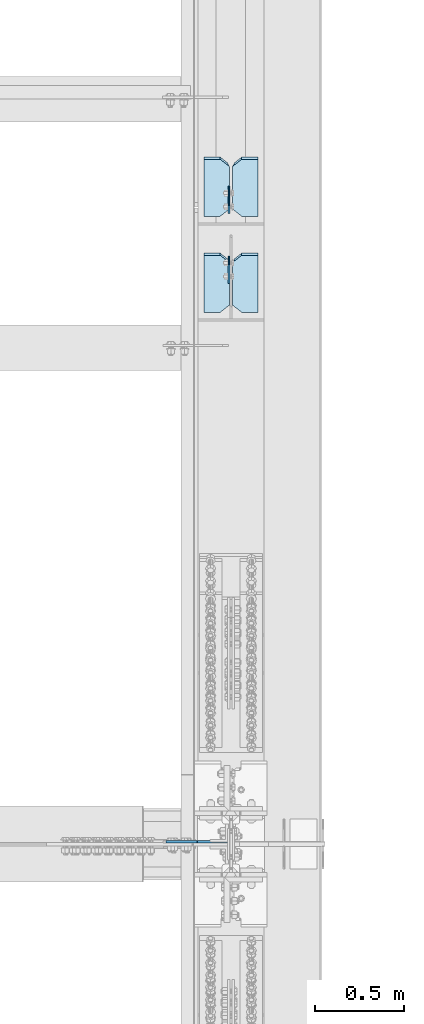
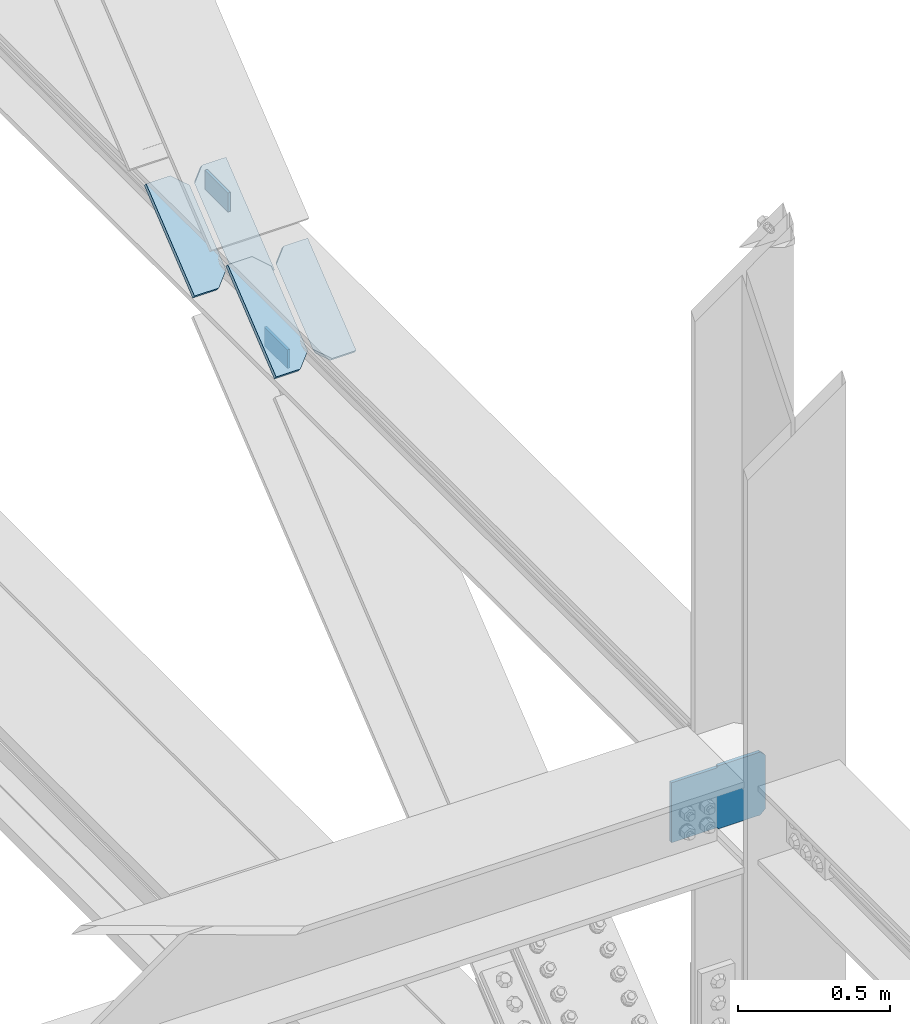
# One storey, part 3608 of 3843: 7 plates, 2 elements without a shape of their own.
"""IFC2X3 building model written with IfcOpenShell, lengths in millimetres."""

from ifc_helpers import new_model, si_unit, frame, origin_with_axes, place, context, subcontext, project, spatial, faceted_brep, material, type_object, element, aggregate, save


model = new_model("IFC2X3")

# Units and contexts
model_context = context("Model", 3, precision=1e-05, world=origin_with_axes())
body_context = subcontext(model_context, "Body", "Model", "MODEL_VIEW")
ifc_project = project(units=[si_unit("LENGTHUNIT", "METRE", prefix="MILLI"), si_unit("AREAUNIT", "SQUARE_METRE"), si_unit("VOLUMEUNIT", "CUBIC_METRE"), si_unit("MASSUNIT", "GRAM", prefix="KILO"), si_unit("TIMEUNIT", "SECOND"), si_unit("PLANEANGLEUNIT", "RADIAN"), si_unit("SOLIDANGLEUNIT", "STERADIAN"), si_unit("THERMODYNAMICTEMPERATUREUNIT", "DEGREE_CELSIUS"), si_unit("LUMINOUSINTENSITYUNIT", "LUMEN")], contexts=[model_context])

# Site, building, storey
site_placement = place(None, origin_with_axes())
site = spatial("IfcSite", under=ifc_project, at=site_placement, CompositionType="ELEMENT")
building_placement = place(site_placement, origin_with_axes())
building = spatial("IfcBuilding", under=site, at=building_placement, Name="Undefined", CompositionType="ELEMENT")
storey_placement = place(building_placement, origin_with_axes())
storey = spatial("IfcBuildingStorey", under=building, at=storey_placement, Name="Undefined", CompositionType="ELEMENT", Elevation=0.0)

# Assembly, plates
assembly_1_placement = place(storey_placement, origin_with_axes())
assembly_1 = element("IfcElementAssembly", 1, at=assembly_1_placement, inside=storey, Name="BEAM", AssemblyPlace="NOTDEFINED", PredefinedType="RIGID_FRAME")
ifc_material = material(Name="STEEL/A572-50")
plate_type_1 = type_object("IfcPlateType", PredefinedType="NOTDEFINED")
plate_1_placement = place(assembly_1_placement, frame((85637.6875, 62213.744979419, 42161.687695586), z_axis=(0.0, 0.000523622999971848, -0.999999862909468), x_axis=(0.0, -0.999999862909468, -0.000523622999970077)))
plate_1 = element("IfcPlate", 2, at=plate_1_placement, type_object=plate_type_1, material=ifc_material, Name="PLATE", context=body_context, shape_type="Brep", body=[
    faceted_brep([(0.0, -4.76249999999709, 0.0), (-3.49245965480804e-10, -4.76249999999709, 76.1999999999462), (-3.49245965480804e-10, 4.76249999999709, 76.1999999999462), (0.0, 4.76249999999709, 0.0), (152.399999999543, -4.76249999999709, 76.199999999495), (152.399999999543, 4.76249999999709, 76.199999999495), (152.399993896484, -4.76249999999709, 0.0), (152.399993896484, 4.76249999999709, 0.0)], [[[0, 1, 2, 3]], [[1, 4, 5, 2]], [[4, 6, 7, 5]], [[6, 0, 3, 7]], [[5, 7, 3, 2]], [[6, 4, 1, 0]]]),
])
plate_2_placement = place(assembly_1_placement, frame((85637.6875, 62605.6469707386, 42555.0432467232), z_axis=(0.0, 0.000523622999971848, -0.999999862909468), x_axis=(0.0, -0.999999862909468, -0.000523622999970077)))
plate_2 = element("IfcPlate", 3, at=plate_2_placement, type_object=plate_type_1, material=ifc_material, Name="PLATE", context=body_context, shape_type="Brep", body=[
    faceted_brep([(0.0, -4.76249999999709, 0.0), (-3.49245965480804e-10, -4.76249999999709, 76.1999999999462), (-3.49245965480804e-10, 4.76249999999709, 76.1999999999462), (0.0, 4.76249999999709, 0.0), (152.399999999543, -4.76249999999709, 76.199999999495), (152.399999999543, 4.76249999999709, 76.199999999495), (152.399993896484, -4.76249999999709, 0.0), (152.399993896484, 4.76249999999709, 0.0)], [[[0, 1, 2, 3]], [[1, 4, 5, 2]], [[4, 6, 7, 5]], [[6, 0, 3, 7]], [[5, 7, 3, 2]], [[6, 4, 1, 0]]]),
])

# Assembly, plate
assembly_2_placement = place(storey_placement, origin_with_axes())
assembly_2 = element("IfcElementAssembly", 4, at=assembly_2_placement, inside=storey, Name="COLUMN", AssemblyPlace="NOTDEFINED", PredefinedType="RIGID_FRAME")
plate_type_2 = type_object("IfcPlateType", PredefinedType="NOTDEFINED")
plate_3_placement = place(assembly_2_placement, frame((85640.8625, 58928.7937500954, 42215.4247183178), z_axis=(-0.707106781186548, 0.0, 0.707106781186548), x_axis=(-0.707106781186548, 0.0, -0.707106781186548)))
plate_3 = element("IfcPlate", 5, at=plate_3_placement, type_object=plate_type_2, material=ifc_material, Name="PLATE", context=body_context, shape_type="Brep", body=[
    faceted_brep([(0.0, -6.3499999046162, 0.0), (-152.665622612301, -6.34999999999854, 152.66562261237), (-152.665622612301, 6.34999999999854, 152.66562261237), (7.27595761418343e-12, 6.3499999046162, 0.0), (-152.66562261201, -6.34999999999854, 179.606390975739), (-152.66562261201, 6.34999999999854, 179.606390975739), (-39.2898891266959, -6.34999999999854, 292.982124550974), (-39.2898891266959, 6.34999999999854, 292.982124550974), (-37.2498776379362, -6.34999999999854, 291.619032453094), (-37.2498776379362, 6.34999999999854, 291.619032453094), (-34.8435200147651, -6.34999999999854, 291.140378161515), (-34.8435200147651, 6.34999999999854, 291.140378161515), (-32.4371623915649, -6.34999999999854, 291.619032453116), (-32.4371623915649, 6.34999999999854, 291.619032453116), (-30.3971509028197, -6.34999999999854, 292.982124551017), (-30.3971509028197, 6.34999999999854, 292.982124551017), (90.8800656821986, -6.34999999999854, 414.259341135985), (90.8800656821986, 6.34999999999854, 414.259341135985), (261.504931981661, -6.34999999999854, 243.634474836461), (261.504931981661, 6.34999999999854, 243.634474836461), (140.316501947716, -6.34999999999854, 122.446044802567), (140.316501947716, 6.34999999999854, 122.446044802567), (138.926191181483, -6.34999999999854, 120.365297697925), (138.926191181483, 6.34999999999854, 120.365297697925), (138.437978964605, -6.34999999999854, 117.910889139548), (138.437978964605, 6.34999999999854, 117.910889139548), (138.926191181454, -6.34999999999854, 115.456480581168), (138.926191181454, 6.34999999999854, 115.456480581168), (140.316501893642, -6.34999999999854, 113.375733530571), (140.316501893642, 6.34999999999854, 113.375733530571), (26.9407683632217, -6.34999999999854, 1.30967237055302e-10), (26.9407683632217, 6.34999999999854, 1.30967237055302e-10)], [[[0, 1, 2, 3]], [[1, 4, 5, 2]], [[4, 6, 7, 5]], [[6, 8, 9, 7]], [[8, 10, 11, 9]], [[10, 12, 13, 11]], [[12, 14, 15, 13]], [[14, 16, 17, 15]], [[16, 18, 19, 17]], [[18, 20, 21, 19]], [[20, 22, 23, 21]], [[22, 24, 25, 23]], [[24, 26, 27, 25]], [[26, 28, 29, 27]], [[28, 30, 31, 29]], [[30, 0, 3, 31]], [[5, 7, 9, 11, 13, 15, 17, 19, 21, 23, 25, 27, 29, 31, 3, 2]], [[30, 28, 26, 24, 22, 20, 18, 16, 14, 12, 10, 8, 6, 4, 1, 0]]]),
])
aggregate(assembly_2, [plate_3])

# Plate
plate_type_3 = type_object("IfcPlateType", PredefinedType="NOTDEFINED")
plate_4_placement = place(assembly_1_placement, frame((85639.275, 61904.5718582238, 42191.314805505), z_axis=(-5.4389238357544e-09, 0.776989877216846, 0.629513090175693), x_axis=(-1.0, 0.0, 0.0)))
plate_4 = element("IfcPlate", 6, at=plate_4_placement, type_object=plate_type_3, material=ifc_material, Name="PLATE", context=body_context, shape_type="Brep", body=[
    faceted_brep([(-3.9668520912528e-08, 9.52500000020336, 50.7999992368859), (11.1124999690801, -9.52499999977772, 39.6874992368976), (11.1124997102015, -9.52499999817701, 371.642537191787), (-2.81215761788189e-07, 9.52500000169493, 360.530037191857), (50.7999989163218, -9.52499999800966, 411.330036428903), (50.7999989162199, 9.52500000192776, 411.33003642899), (142.875002731016, -9.52499999803877, 411.330036429456), (142.875002730914, 9.52500000189866, 411.330036429557), (142.875003051784, -9.52500000001055, 7.8580342233181e-10), (142.875003051697, 9.5249999999196, 8.87666828930378e-10), (50.7999992370897, -9.52499999998145, 2.47382558882236e-10), (50.7999992370023, 9.5249999999487, 3.49245965480804e-10)], [[[0, 1, 2, 3]], [[4, 5, 3, 2]], [[4, 6, 7, 5]], [[6, 8, 9, 7]], [[8, 10, 11, 9]], [[11, 10, 1, 0]], [[5, 7, 9, 11, 0, 3]], [[10, 8, 6, 4, 2, 1]]]),
])

plate_5_placement = place(assembly_1_placement, frame((85658.325, 61904.5567380002, 42191.3344067096), z_axis=(4.66218625660986e-09, 0.777027750892754, 0.629466340913117), x_axis=(1.0, 0.0, 0.0)))
plate_5 = element("IfcPlate", 7, at=plate_5_placement, type_object=plate_type_3, material=ifc_material, Name="PLATE", context=body_context, shape_type="Brep", body=[
    faceted_brep([(-1.3597309589386e-07, -9.52500000151849, 360.529446917775), (11.1124998599262, 9.52499999852807, 371.641946917822), (11.1124999850872, 9.52499999989595, 39.687499236883), (-1.91939761862159e-08, -9.52500000023792, 50.7999992367113), (50.7999990819371, -9.52500000170767, 411.329446154603), (50.7999990820244, 9.524999998368, 411.329446154705), (142.875002896631, -9.52500000168584, 411.329446154734), (142.875002896719, 9.52499999840438, 411.329446154836), (142.875003051784, -9.52500000001055, 7.8580342233181e-10), (142.875003051697, 9.5249999999196, 8.87666828930378e-10), (50.7999992370897, -9.52499999998145, 2.47382558882236e-10), (50.7999992370023, 9.5249999999487, 3.49245965480804e-10)], [[[0, 1, 2, 3]], [[4, 5, 1, 0]], [[4, 6, 7, 5]], [[6, 8, 9, 7]], [[8, 10, 11, 9]], [[11, 10, 3, 2]], [[5, 7, 9, 11, 2, 1]], [[10, 8, 6, 4, 0, 3]]]),
])

plate_6_placement = place(assembly_1_placement, frame((85639.275, 62443.1962639938, 42190.4690885428), z_axis=(-8.36885340686425e-06, 0.777036426466805, 0.629455631378145), x_axis=(-0.999999999964979, -6.50800002238309e-06, -5.26199998460654e-06)))
plate_6 = element("IfcPlate", 8, at=plate_6_placement, type_object=plate_type_3, material=ifc_material, Name="PLATE", context=body_context, shape_type="Brep", body=[
    faceted_brep([(-3.9668520912528e-08, 9.52500000020336, 50.7999992368859), (11.1124999690801, -9.52499999977772, 39.6874992368976), (11.1124997113075, -9.52499999958673, 371.69791821012), (-2.80255335383117e-07, 9.52500000044529, 360.585418209899), (50.7999989177479, -9.52499999971769, 411.385417447702), (50.7999989176315, 9.52500000028522, 411.3854174476), (142.87500273301, -9.52500000013242, 411.385417448473), (142.875002732893, 9.52499999986321, 411.385417448386), (142.875003051784, -9.52500000001055, 7.8580342233181e-10), (142.875003051697, 9.5249999999196, 8.87666828930378e-10), (50.7999992370897, -9.52499999998145, 2.47382558882236e-10), (50.7999992370023, 9.5249999999487, 3.49245965480804e-10)], [[[0, 1, 2, 3]], [[4, 5, 3, 2]], [[4, 6, 7, 5]], [[6, 8, 9, 7]], [[8, 10, 11, 9]], [[11, 10, 1, 0]], [[5, 7, 9, 11, 0, 3]], [[10, 8, 6, 4, 2, 1]]]),
])

plate_7_placement = place(assembly_1_placement, frame((85658.325, 62443.1962639227, 42190.46908854), z_axis=(8.36885340686425e-06, 0.777036426466805, 0.629455631378145), x_axis=(0.999999999964985, -6.50699995062344e-06, -5.26199998460604e-06)))
plate_7 = element("IfcPlate", 9, at=plate_7_placement, type_object=plate_type_3, material=ifc_material, Name="PLATE", context=body_context, shape_type="Brep", body=[
    faceted_brep([(-1.37792085297406e-07, -9.52500000045802, 360.585418209928), (11.1124998579326, 9.52499999950123, 371.697918210004), (11.1124999850872, 9.52499999989595, 39.687499236883), (-1.91939761862159e-08, -9.52500000023792, 50.7999992367113), (50.7999989177479, -9.52499999971769, 411.385417447702), (50.7999989176315, 9.52500000028522, 411.3854174476), (142.87500273301, -9.52500000013242, 411.385417448473), (142.875002732893, 9.52499999986321, 411.385417448386), (142.875003051784, -9.52500000001055, 7.8580342233181e-10), (142.875003051697, 9.5249999999196, 8.87666828930378e-10), (50.7999992370897, -9.52499999998145, 2.47382558882236e-10), (50.7999992370023, 9.5249999999487, 3.49245965480804e-10)], [[[0, 1, 2, 3]], [[4, 5, 1, 0]], [[4, 6, 7, 5]], [[6, 8, 9, 7]], [[8, 10, 11, 9]], [[11, 10, 3, 2]], [[5, 7, 9, 11, 2, 1]], [[10, 8, 6, 4, 0, 3]]]),
])

aggregate(assembly_1, [plate_1, plate_2, plate_4, plate_5, plate_6, plate_7])

save(model, "model.ifc")
